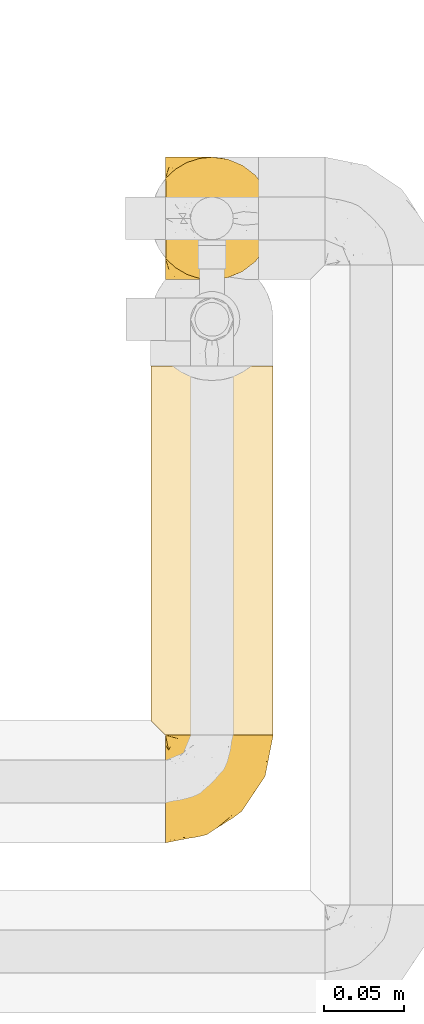
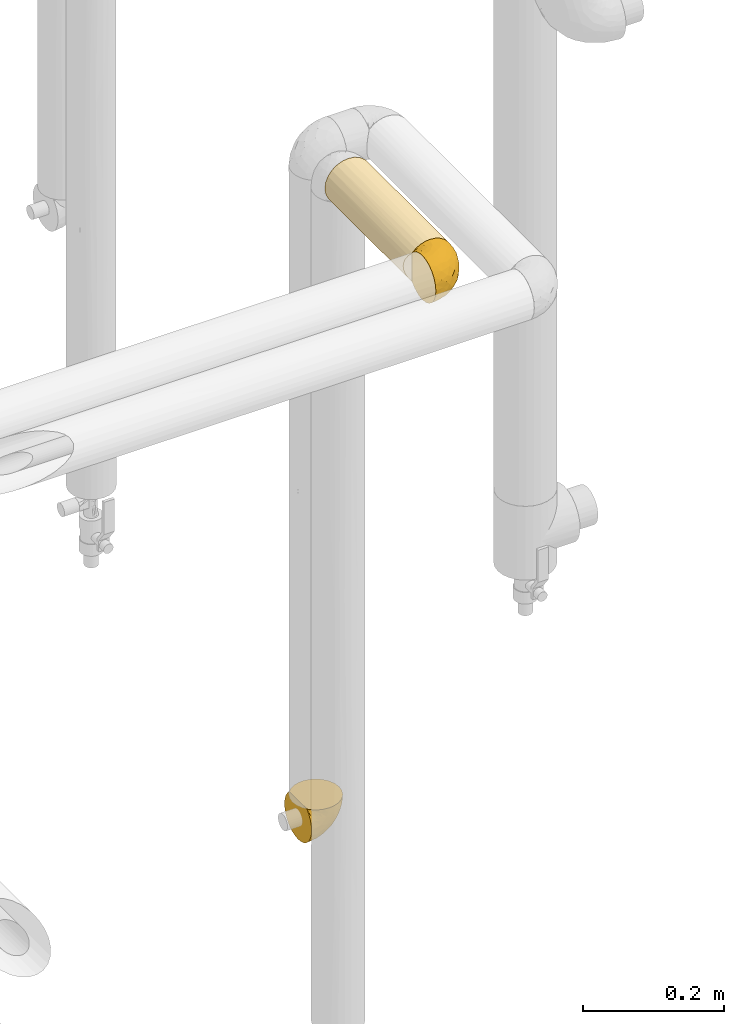
# One storey, part 86 of 827: 3 coverings.
"""IFC2X3 building model written with IfcOpenShell, lengths in millimetres."""

import ifcopenshell
import ifcopenshell.guid

model = None  # the IFC model being written
_history = None  # IfcOwnerHistory: only IFC2X3 demands one
_inside = {}  # id of a spatial element -> (the spatial element, [elements in it])
_under = {}  # id of a project, library or spatial element -> (it, [spatial elements below it])
_declared = {}  # id of a project -> (the project, [libraries it declares])
_typed = {}  # id of a type object -> (the type object, [elements of that type])
_made_of = {}  # id of a material, layer set ... -> (it, [elements and type objects made of it])


def new_model(schema):
    """Start an empty IFC model of exactly this schema.

    Asked for "IFC4X3", IfcOpenShell would pick the latest addendum, in which some entities
    have other attributes; the version numbers below select the first issue.
    IFC2X3 requires an IfcOwnerHistory on every rooted entity: one is made here for all.
    """
    global model, _history
    if schema == "IFC4X3":
        model = ifcopenshell.file(schema_version=(4, 3, 0, 0))
    else:
        model = ifcopenshell.file(schema=schema)
    _inside.clear()
    _under.clear()
    _declared.clear()
    _typed.clear()
    _made_of.clear()
    _history = None
    if model.schema == "IFC2X3":
        org = make("IfcOrganization", Name="unknown")
        user = make(
            "IfcPersonAndOrganization",
            ThePerson=make("IfcPerson", FamilyName="unknown"),
            TheOrganization=org,
        )
        app = make(
            "IfcApplication",
            ApplicationDeveloper=org,
            Version="unknown",
            ApplicationFullName="unknown",
            ApplicationIdentifier="unknown",
        )
        _history = make(
            "IfcOwnerHistory",
            OwningUser=user,
            OwningApplication=app,
            ChangeAction="ADDED",
            CreationDate=0,
        )
    return model


def make(cls, **values):
    """One entity of the class cls with the attributes given. An attribute that is None is left unset."""
    return model.create_entity(
        cls, **{name: value for name, value in values.items() if value is not None}
    )


def entity(cls, *values):
    """Any entity or typed value of the class cls, its attributes in the order of the schema. None: left unset."""
    e = model.create_entity(cls)
    for i, value in enumerate(values):
        if value is not None:
            e[i] = value
    return e


def rooted(cls, **values):
    """An entity with a GlobalId (a new one), such as an element, a storey or a relation."""
    return make(cls, GlobalId=ifcopenshell.guid.new(), OwnerHistory=_history, **values)


def si_unit(unit_type, name, prefix=None):
    """IfcSIUnit, for example si_unit("LENGTHUNIT", "METRE", prefix="MILLI")."""
    return make("IfcSIUnit", UnitType=unit_type, Prefix=prefix, Name=name)


def converted_unit(unit_type, name, factor, base, dimensions=None, offset=None):
    """IfcConversionBasedUnit, such as the inch: factor (a typed value) times the base unit."""
    return make(
        "IfcConversionBasedUnit"
        if offset is None
        else "IfcConversionBasedUnitWithOffset",
        ConversionOffset=offset,
        Dimensions=None
        if dimensions is None
        else entity("IfcDimensionalExponents", *dimensions),
        UnitType=unit_type,
        Name=name,
        ConversionFactor=make(
            "IfcMeasureWithUnit", ValueComponent=factor, UnitComponent=base
        ),
    )


def derived_unit(unit_type, elements):
    """IfcDerivedUnit: a product of units, each with its exponent."""
    return make(
        "IfcDerivedUnit",
        Elements=[
            make("IfcDerivedUnitElement", Unit=unit, Exponent=power)
            for unit, power in elements
        ],
        UnitType=unit_type,
    )


def assignment(units):
    """IfcUnitAssignment: the units of a project."""
    return None if units is None else make("IfcUnitAssignment", Units=units)


def point(xyz):
    """IfcCartesianPoint."""
    return None if xyz is None else make("IfcCartesianPoint", Coordinates=xyz)


def direction(xyz):
    """IfcDirection."""
    return None if xyz is None else make("IfcDirection", DirectionRatios=xyz)


def frame(location, z_axis=None, x_axis=None):
    """IfcAxis2Placement3D, a coordinate frame: its origin and axes. An axis left out is left unset."""
    return make(
        "IfcAxis2Placement3D",
        Location=point(location),
        Axis=direction(z_axis),
        RefDirection=direction(x_axis),
    )


def origin():
    """The frame at (0, 0, 0) with its axes left unset."""
    return frame((0.0, 0.0, 0.0))


def place(relative_to, where):
    """IfcLocalPlacement: puts the frame where relative to a parent placement (None: the world)."""
    return make(
        "IfcLocalPlacement", PlacementRelTo=relative_to, RelativePlacement=where
    )


def context(
    kind, dimensions, precision=None, world=None, true_north=None, identifier=None
):
    """IfcGeometricRepresentationContext, for example the 3D "Model" context."""
    return make(
        "IfcGeometricRepresentationContext",
        ContextIdentifier=identifier,
        ContextType=kind,
        CoordinateSpaceDimension=dimensions,
        Precision=precision,
        WorldCoordinateSystem=world,
        TrueNorth=true_north,
    )


def subcontext(parent, identifier, kind, view, scale=None):
    """IfcGeometricRepresentationSubContext, for example "Body" below "Model"."""
    return make(
        "IfcGeometricRepresentationSubContext",
        ContextIdentifier=identifier,
        ContextType=kind,
        ParentContext=parent,
        TargetScale=scale,
        TargetView=view,
    )


def project(units=None, contexts=None):
    """IfcProject with its units and contexts."""
    return rooted(
        "IfcProject",
        Name="project",
        RepresentationContexts=contexts,
        UnitsInContext=assignment(units),
    )


def spatial(cls, under=None, at=None, **own):
    """A site, building, storey or space (cls), placed at a placement, below another one or the project."""
    s = rooted(cls, ObjectPlacement=at, **own)
    if under is not None:
        _under.setdefault(under.id(), (under, []))[1].append(s)
    return s


def faces_of(points, faces, orient=None, outer=None):
    """IfcFace entities. A face is a list of loops; a loop is a list of indices into points, from 0.

    orient and outer hold one flag for each loop. By default every Orientation is true, the
    first loop of a face is its IfcFaceOuterBound and the others are IfcFaceBound.
    """
    made = []
    for i, loops in enumerate(faces):
        bounds = []
        for j, loop in enumerate(loops):
            is_outer = j == 0 if outer is None else outer[i][j]
            bounds.append(
                make(
                    "IfcFaceOuterBound" if is_outer else "IfcFaceBound",
                    Bound=make("IfcPolyLoop", Polygon=[points[k] for k in loop]),
                    Orientation=True if orient is None else orient[i][j],
                )
            )
        made.append(make("IfcFace", Bounds=bounds))
    return made


def faceted_brep(points, faces, orient=None, outer=None, voids=None):
    """IfcFacetedBrep: a solid bounded by flat faces; with voids (closed shells), ...WithVoids."""
    shared = [point(p) for p in points]
    hull = make("IfcClosedShell", CfsFaces=faces_of(shared, faces, orient, outer))
    if voids is None:
        return make("IfcFacetedBrep", Outer=hull)
    return make(
        "IfcFacetedBrepWithVoids",
        Outer=hull,
        Voids=[
            make(cls, CfsFaces=faces_of(shared, fs, o, b)) for cls, fs, o, b in voids
        ],
    )


def shape(context_of_items, identifier, shape_type, items):
    """IfcShapeRepresentation: the items that make up one representation, for example the "Body"."""
    return make(
        "IfcShapeRepresentation",
        ContextOfItems=context_of_items,
        RepresentationIdentifier=identifier,
        RepresentationType=shape_type,
        Items=items,
    )


def made_of(thing, what):
    """Note that an element or type object is made of a material, layer set ...; save() writes the relation."""
    if what is not None:
        _made_of.setdefault(what.id(), (what, []))[1].append(thing)
    return thing


def element(
    cls,
    number,
    at=None,
    inside=None,
    cuts=None,
    type_object=None,
    material=None,
    context=None,
    identifier="Body",
    shape_type=None,
    held_by="IfcProductDefinitionShape",
    body=None,
    shapes=None,
    **own,
):
    """One element of the class cls, such as IfcWall. Its Tag is "e" and its number.

    at: its placement. inside: the storey or other place that contains it. cuts: it is an
    opening in that element (IfcRelVoidsElement). A single representation is given by context,
    identifier, shape_type and body (its items); several are given by shapes. held_by: the class
    of the entity that holds the representations. save() writes the other relations.
    """
    e = rooted(cls, Tag="e%d" % number, ObjectPlacement=at, **own)
    if body is not None:
        shapes = [shape(context, identifier, shape_type, body)]
    if shapes is not None:
        e.Representation = make(held_by, Representations=shapes)
    if inside is not None:
        _inside.setdefault(inside.id(), (inside, []))[1].append(e)
    if cuts is not None:
        rooted(
            "IfcRelVoidsElement", RelatingBuildingElement=cuts, RelatedOpeningElement=e
        )
    if type_object is not None:
        _typed.setdefault(type_object.id(), (type_object, []))[1].append(e)
    return made_of(e, material)


def aggregate(whole, parts):
    """IfcRelAggregates: a whole, such as a stair, and the parts it consists of."""
    return rooted("IfcRelAggregates", RelatingObject=whole, RelatedObjects=parts)


def save(model, path):
    """Write the relations noted so far, then the file.

    IfcRelAggregates (storeys below a building ...), IfcRelContainedInSpatialStructure (elements
    in a storey), IfcRelDefinesByType, IfcRelAssociatesMaterial and IfcRelDeclares: one each for
    every whole, place, type object, material and project.
    """
    for whole, parts in _under.values():
        aggregate(whole, parts)
    for where, things in _inside.values():
        rooted(
            "IfcRelContainedInSpatialStructure",
            RelatedElements=things,
            RelatingStructure=where,
        )
    for kind, things in _typed.values():
        rooted("IfcRelDefinesByType", RelatedObjects=things, RelatingType=kind)
    for what, things in _made_of.values():
        rooted("IfcRelAssociatesMaterial", RelatedObjects=things, RelatingMaterial=what)
    for by, libraries in _declared.values():
        rooted("IfcRelDeclares", RelatingContext=by, RelatedDefinitions=libraries)
    model.write(path)


model = new_model("IFC2X3")

# Units and contexts
model_context = context("Model", 3, precision=0.01, world=origin(), true_north=direction((6.12303176911189e-17, 1.0)))
body_context = subcontext(model_context, "Body", "Model", "MODEL_VIEW")
ifc_project = project(units=[si_unit("LENGTHUNIT", "METRE", prefix="MILLI"), si_unit("AREAUNIT", "SQUARE_METRE"), si_unit("VOLUMEUNIT", "CUBIC_METRE"), converted_unit("PLANEANGLEUNIT", "DEGREE", entity("IfcRatioMeasure", 0.0174532925199433), si_unit("PLANEANGLEUNIT", "RADIAN"), dimensions=[0, 0, 0, 0, 0, 0, 0]), si_unit("MASSUNIT", "GRAM", prefix="KILO"), derived_unit("MASSDENSITYUNIT", [(si_unit("MASSUNIT", "GRAM", prefix="KILO"), 1), (si_unit("LENGTHUNIT", "METRE"), -3)]), derived_unit("MOMENTOFINERTIAUNIT", [(si_unit("LENGTHUNIT", "METRE"), 4)]), si_unit("TIMEUNIT", "SECOND"), si_unit("FREQUENCYUNIT", "HERTZ"), si_unit("THERMODYNAMICTEMPERATUREUNIT", "DEGREE_CELSIUS"), derived_unit("THERMALTRANSMITTANCEUNIT", [(si_unit("MASSUNIT", "GRAM", prefix="KILO"), 1), (si_unit("THERMODYNAMICTEMPERATUREUNIT", "KELVIN"), -1), (si_unit("TIMEUNIT", "SECOND"), -3)]), derived_unit("VOLUMETRICFLOWRATEUNIT", [(si_unit("LENGTHUNIT", "METRE"), 3), (si_unit("TIMEUNIT", "SECOND"), -1)]), derived_unit("MASSFLOWRATEUNIT", [(si_unit("MASSUNIT", "GRAM", prefix="KILO"), 1), (si_unit("TIMEUNIT", "SECOND"), -1)]), derived_unit("ROTATIONALFREQUENCYUNIT", [(si_unit("TIMEUNIT", "SECOND"), -1)]), si_unit("ELECTRICCURRENTUNIT", "AMPERE"), si_unit("ELECTRICVOLTAGEUNIT", "VOLT"), si_unit("POWERUNIT", "WATT"), si_unit("FORCEUNIT", "NEWTON", prefix="KILO"), si_unit("ILLUMINANCEUNIT", "LUX"), si_unit("LUMINOUSFLUXUNIT", "LUMEN"), si_unit("LUMINOUSINTENSITYUNIT", "CANDELA"), derived_unit("USERDEFINED", [(si_unit("MASSUNIT", "GRAM", prefix="KILO"), -1), (si_unit("LENGTHUNIT", "METRE"), -2), (si_unit("TIMEUNIT", "SECOND"), 3), (si_unit("LUMINOUSFLUXUNIT", "LUMEN"), 1)]), derived_unit("LINEARVELOCITYUNIT", [(si_unit("LENGTHUNIT", "METRE"), 1), (si_unit("TIMEUNIT", "SECOND"), -1)]), si_unit("PRESSUREUNIT", "PASCAL"), derived_unit("USERDEFINED", [(si_unit("LENGTHUNIT", "METRE"), -2), (si_unit("MASSUNIT", "GRAM", prefix="KILO"), 1), (si_unit("TIMEUNIT", "SECOND"), -2)]), derived_unit("LINEARFORCEUNIT", [(si_unit("MASSUNIT", "GRAM", prefix="KILO"), 1), (si_unit("LENGTHUNIT", "METRE"), 1), (si_unit("TIMEUNIT", "SECOND"), -2), (si_unit("LENGTHUNIT", "METRE"), -1)]), derived_unit("PLANARFORCEUNIT", [(si_unit("MASSUNIT", "GRAM", prefix="KILO"), 1), (si_unit("LENGTHUNIT", "METRE"), 1), (si_unit("TIMEUNIT", "SECOND"), -2), (si_unit("LENGTHUNIT", "METRE"), -2)])], contexts=[model_context])

# Site, building, storey
site_placement = place(None, origin())
site = spatial("IfcSite", under=ifc_project, at=site_placement, CompositionType="ELEMENT")
building_placement = place(site_placement, origin())
building = spatial("IfcBuilding", under=site, at=building_placement, CompositionType="ELEMENT")
storey_placement = place(building_placement, frame((0.0, 0.0, 28200.0)))
storey = spatial("IfcBuildingStorey", under=building, at=storey_placement, Name="08", CompositionType="ELEMENT", Elevation=28200.0)

# Coverings
covering_1_placement = place(storey_placement, frame((18855.44, 12179.47, 709.95)))
element("IfcCovering", 1, at=covering_1_placement, inside=storey, Name=":ADSK_", ObjectType=":ADSK_", PredefinedType="INSULATION", context=body_context, shape_type="Brep", body=[
    faceted_brep([(1.6, 74.68, 23.36), (1.6, 70.1, 16.07), (1.6, 64.01, 9.98), (1.6, 56.72, 5.4), (1.6, 48.6, 2.56), (1.6, 40.05, 1.6), (1.6, 31.49, 2.56), (1.6, 23.36, 5.41), (1.6, 16.07, 9.99), (1.6, 9.98, 16.08), (1.6, 5.4, 23.37), (1.6, 2.56, 31.49), (1.6, 1.6, 40.05), (1.6, 2.46, 48.15), (1.6, 5.01, 55.88), (1.6, 9.13, 62.9), (1.6, 14.62, 68.89), (1.6, 16.82, 68.89), (1.6, 18.56, 68.89), (1.6, 20.52, 68.89), (1.6, 22.49, 68.89), (1.6, 24.46, 68.89), (1.6, 26.42, 68.89), (1.6, 28.39, 68.89), (1.6, 30.36, 68.89), (1.6, 32.55, 68.89), (1.6, 34.75, 68.89), (1.6, 36.94, 68.89), (1.6, 39.13, 68.89), (1.6, 41.33, 68.89), (1.6, 43.52, 68.89), (1.6, 45.72, 68.89), (1.6, 47.91, 68.89), (1.6, 50.11, 68.89), (1.6, 52.3, 68.89), (1.6, 54.49, 68.89), (1.6, 56.69, 68.89), (1.6, 58.88, 68.89), (1.6, 61.08, 68.89), (1.6, 63.27, 68.89), (1.6, 65.47, 68.89), (1.6, 70.97, 62.89), (1.6, 75.09, 55.86), (1.6, 77.64, 48.13), (1.6, 78.5, 40.05), (1.6, 77.53, 31.49), (1.85, 14.62, 69.15), (7.85, 9.12, 69.15), (14.87, 5.0, 69.15), (22.6, 2.46, 69.15), (30.7, 1.6, 69.15), (40.65, 2.91, 69.15), (49.92, 6.75, 69.15), (57.88, 12.86, 69.15), (63.99, 20.82, 69.15), (67.84, 30.09, 69.15), (69.15, 40.05, 69.15), (67.84, 50.0, 69.15), (63.99, 59.27, 69.15), (57.88, 67.23, 69.15), (49.92, 73.34, 69.15), (40.65, 77.19, 69.15), (30.7, 78.5, 69.15), (22.6, 77.63, 69.15), (14.87, 75.09, 69.15), (7.85, 70.97, 69.15), (1.85, 65.47, 69.15), (1.85, 63.27, 69.15), (1.85, 62.29, 69.15), (1.85, 60.7, 69.15), (1.85, 59.11, 69.15), (1.85, 57.52, 69.15), (1.85, 55.93, 69.15), (1.85, 54.34, 69.15), (1.85, 52.76, 69.15), (1.85, 51.17, 69.15), (1.85, 49.58, 69.15), (1.85, 47.99, 69.15), (1.85, 46.4, 69.15), (1.85, 44.81, 69.15), (1.85, 43.22, 69.15), (1.85, 41.63, 69.15), (1.85, 40.05, 69.15), (1.85, 38.46, 69.15), (1.85, 36.87, 69.15), (1.85, 35.28, 69.15), (1.85, 33.69, 69.15), (1.85, 32.1, 69.15), (1.85, 30.51, 69.15), (1.85, 28.92, 69.15), (1.85, 27.33, 69.15), (1.85, 25.37, 69.15), (1.85, 23.4, 69.15), (1.85, 21.21, 69.15), (1.85, 19.01, 69.15), (1.85, 16.82, 69.15), (1.77, 42.32, 68.96), (1.78, 44.02, 68.97), (1.77, 47.13, 68.97), (1.77, 48.74, 68.97), (1.76, 23.57, 68.95), (1.77, 25.13, 68.96), (1.79, 61.34, 68.98), (1.78, 22.02, 68.97), (1.78, 29.72, 68.97), (1.78, 56.73, 68.98), (1.78, 55.14, 68.97), (1.78, 37.66, 68.97), (1.74, 64.12, 68.94), (1.78, 28.13, 68.98), (1.78, 26.62, 68.98), (1.77, 31.46, 68.96), (1.78, 16.16, 68.97), (1.78, 39.16, 68.98), (1.78, 50.37, 68.98), (1.77, 17.69, 68.97), (1.77, 19.17, 68.96), (1.77, 62.78, 68.97), (1.78, 58.35, 68.97), (1.78, 45.53, 68.98), (1.77, 59.91, 68.96), (1.77, 65.47, 68.97), (1.72, 65.47, 68.94), (1.66, 65.47, 68.92), (1.77, 14.62, 68.97), (1.8, 14.62, 69.02), (1.82, 14.62, 69.08), (1.79, 20.59, 68.98), (1.78, 32.99, 68.97), (1.79, 34.48, 68.98), (1.78, 51.91, 68.97), (1.82, 65.47, 69.08), (1.8, 65.47, 69.02), (1.76, 53.48, 68.96), (1.66, 14.62, 68.92), (1.72, 14.62, 68.94), (1.78, 40.77, 68.97), (1.77, 35.97, 68.96), (9.41, 7.84, 67.02), (17.65, 3.53, 63.33), (7.41, 8.32, 64.61), (15.21, 2.19, 51.4), (7.41, 3.53, 53.1), (16.15, 1.6, 43.94), (28.75, 1.6, 61.87), (13.67, 4.57, 61.54), (12.79, 3.96, 57.95), (19.18, 2.28, 56.12), (29.16, 1.6, 63.4), (9.04, 7.69, 65.41), (5.74, 8.32, 63.04), (3.72, 7.84, 61.33), (8.87, 1.6, 41.99), (21.47, 1.6, 49.27), (26.8, 1.6, 54.6), (9.53, 4.34, 56.6), (7.34, 1.6, 41.58), (37.63, 29.63, 13.72), (17.92, 27.34, 5.82), (27.45, 40.05, 6.74), (37.01, 2.39, 58.82), (34.22, 2.43, 51.58), (45.87, 9.07, 42.09), (56.57, 16.64, 46.12), (52.31, 9.54, 55.56), (42.07, 4.52, 52.38), (44.74, 4.52, 61.54), (21.49, 7.49, 23.76), (11.02, 7.49, 20.5), (15.64, 12.85, 14.64), (26.02, 2.35, 41.77), (36.59, 22.66, 16.28), (65.49, 32.9, 49.4), (63.99, 25.33, 52.34), (15.2, 40.05, 4.3), (60.27, 16.64, 58.67), (45.25, 19.99, 25.26), (35.21, 16.37, 20.17), (22.52, 3.26, 34.7), (12.03, 3.75, 28.67), (13.32, 19.58, 8.62), (35.9, 7.5, 33.37), (33.87, 4.04, 41.35), (25.73, 13.94, 17.15), (26.34, 19.58, 12.68), (46.78, 28.21, 21.47), (59.54, 24.75, 41.11), (60.18, 31.42, 37.53), (53.93, 26.2, 30.64), (53.36, 33.36, 26.66), (49.36, 40.05, 21.38), (38.4, 40.05, 14.06), (66.44, 40.05, 55.54), (50.09, 16.14, 35.17), (41.08, 12.85, 29.04), (31.14, 10.47, 24.34), (28.19, 6.49, 29.33), (64.0, 40.05, 43.3), (56.68, 40.05, 32.34), (43.9, 75.57, 57.75), (65.46, 47.37, 49.41), (52.22, 52.91, 27.85), (37.61, 50.46, 13.7), (15.64, 67.23, 14.63), (13.31, 60.5, 8.61), (50.02, 70.55, 48.85), (59.28, 63.45, 54.13), (53.05, 62.61, 37.84), (21.48, 72.6, 23.75), (11.01, 72.6, 20.49), (12.03, 76.34, 28.66), (41.02, 59.34, 20.83), (35.39, 77.76, 55.15), (26.8, 78.5, 54.6), (28.75, 78.5, 61.87), (7.34, 78.5, 41.58), (65.81, 53.16, 57.58), (53.28, 70.55, 59.91), (59.8, 48.88, 36.94), (61.82, 54.76, 45.72), (17.91, 52.74, 5.82), (41.4, 71.93, 37.91), (40.48, 75.79, 50.18), (26.34, 60.5, 12.67), (31.68, 77.86, 49.29), (27.68, 77.64, 42.64), (16.15, 78.5, 43.94), (21.47, 78.5, 49.27), (28.05, 67.23, 19.45), (22.54, 76.82, 34.7), (8.87, 78.5, 41.99), (37.3, 77.8, 62.29), (41.07, 67.23, 29.01), (32.24, 73.2, 31.47), (47.4, 67.66, 37.18), (35.77, 75.99, 43.45), (17.65, 76.57, 63.33), (11.06, 73.21, 67.23), (8.55, 71.93, 66.07), (6.63, 71.07, 65.22), (12.77, 75.09, 61.99), (12.79, 76.13, 57.95), (7.41, 76.57, 53.09), (18.97, 77.69, 56.84), (3.72, 72.26, 61.33), (5.76, 71.77, 63.06), (15.21, 77.9, 51.41), (9.52, 75.75, 56.61)], [[[0, 1, 2, 3, 4, 5, 6, 7, 8, 9, 10, 11, 12, 13, 14, 15, 16, 17, 18, 19, 20, 21, 22, 23, 24, 25, 26, 27, 28, 29, 30, 31, 32, 33, 34, 35, 36, 37, 38, 39, 40, 41, 42, 43, 44, 45]], [[46, 47, 48, 49, 50, 51, 52, 53, 54, 55, 56, 57, 58, 59, 60, 61, 62, 63, 64, 65, 66, 67, 68, 69, 70, 71, 72, 73, 74, 75, 76, 77, 78, 79, 80, 81, 82, 83, 84, 85, 86, 87, 88, 89, 90, 91, 92, 93, 94, 95]], [[96, 97, 30]], [[98, 77, 99]], [[100, 101, 21]], [[69, 68, 102]], [[20, 19, 103]], [[24, 23, 104]], [[20, 103, 100]], [[72, 105, 106]], [[84, 83, 107]], [[89, 88, 104]], [[108, 67, 66]], [[109, 110, 90]], [[111, 25, 24]], [[112, 17, 16]], [[82, 113, 83]], [[109, 23, 22]], [[114, 76, 75]], [[105, 36, 106]], [[104, 111, 24]], [[18, 115, 116]], [[97, 96, 80]], [[67, 108, 117]], [[105, 71, 118]], [[31, 97, 119]], [[102, 120, 69]], [[108, 121, 122, 123, 40]], [[112, 95, 115]], [[17, 115, 18]], [[94, 116, 115]], [[117, 68, 67]], [[38, 117, 39]], [[112, 124, 125, 126, 46]], [[17, 112, 115]], [[70, 120, 118]], [[39, 117, 108]], [[120, 38, 37]], [[120, 37, 118]], [[120, 70, 69]], [[116, 94, 127]], [[128, 86, 129]], [[117, 38, 102]], [[74, 130, 75]], [[99, 33, 32]], [[115, 95, 94]], [[39, 108, 40]], [[108, 66, 131, 132, 121]], [[105, 72, 71]], [[118, 37, 36]], [[71, 70, 118]], [[35, 106, 36]], [[36, 105, 118]], [[35, 133, 106]], [[74, 73, 133]], [[106, 133, 73]], [[99, 114, 33]], [[133, 35, 34]], [[73, 72, 106]], [[95, 112, 46]], [[112, 16, 134, 135, 124]], [[130, 114, 75]], [[99, 76, 114]], [[114, 130, 33]], [[34, 33, 130]], [[78, 77, 98]], [[98, 119, 78]], [[130, 133, 34]], [[133, 130, 74]], [[79, 97, 80]], [[98, 99, 32]], [[98, 32, 31]], [[77, 76, 99]], [[97, 79, 119]], [[136, 96, 29]], [[30, 97, 31]], [[136, 29, 28]], [[81, 80, 96]], [[29, 96, 30]], [[31, 119, 98]], [[119, 79, 78]], [[96, 136, 81]], [[82, 81, 136]], [[113, 107, 83]], [[84, 107, 137]], [[107, 27, 137]], [[113, 28, 107]], [[27, 107, 28]], [[85, 84, 137]], [[137, 27, 26]], [[113, 136, 28]], [[136, 113, 82]], [[109, 89, 104]], [[86, 85, 129]], [[89, 109, 90]], [[111, 87, 128]], [[26, 129, 137]], [[88, 111, 104]], [[25, 111, 128]], [[22, 110, 109]], [[23, 109, 104]], [[110, 91, 90]], [[100, 92, 101]], [[110, 22, 101]], [[91, 110, 101]], [[116, 19, 18]], [[111, 88, 87]], [[127, 103, 19]], [[25, 128, 26]], [[86, 128, 87]], [[128, 129, 26]], [[137, 129, 85]], [[120, 102, 38]], [[117, 102, 68]], [[91, 101, 92]], [[21, 101, 22]], [[93, 92, 103]], [[100, 21, 20]], [[100, 103, 92]], [[127, 93, 103]], [[93, 127, 94]], [[116, 127, 19]], [[126, 138, 47]], [[48, 138, 139]], [[140, 125, 124]], [[141, 142, 143]], [[144, 49, 139]], [[145, 140, 146]], [[48, 139, 49]], [[139, 145, 147]], [[49, 144, 148, 50]], [[126, 125, 149]], [[14, 13, 142]], [[150, 146, 140]], [[149, 140, 145]], [[151, 150, 135]], [[151, 14, 142]], [[16, 15, 134]], [[13, 152, 142]], [[124, 150, 140]], [[141, 143, 153]], [[14, 151, 15]], [[15, 151, 134]], [[47, 46, 126]], [[139, 154, 144]], [[138, 48, 47]], [[125, 140, 149]], [[135, 134, 151]], [[146, 155, 141]], [[145, 146, 147]], [[149, 139, 138]], [[147, 153, 154]], [[147, 146, 141]], [[139, 147, 154]], [[139, 149, 145]], [[149, 138, 126]], [[147, 141, 153]], [[146, 150, 155]], [[151, 155, 150]], [[142, 141, 155]], [[13, 12, 156, 152]], [[152, 143, 142]], [[151, 142, 155]], [[150, 124, 135]], [[157, 158, 159]], [[160, 154, 161]], [[162, 163, 164]], [[165, 166, 160]], [[167, 168, 169]], [[153, 170, 161]], [[156, 12, 11]], [[158, 157, 171]], [[172, 55, 173]], [[158, 6, 174]], [[175, 54, 53]], [[52, 166, 164]], [[52, 164, 53]], [[54, 175, 173]], [[166, 52, 51]], [[176, 177, 171]], [[178, 143, 179]], [[156, 11, 179]], [[8, 7, 180]], [[169, 9, 8]], [[179, 143, 152, 156]], [[179, 11, 10]], [[168, 179, 10]], [[181, 162, 182]], [[179, 167, 178]], [[183, 184, 177]], [[183, 169, 184]], [[176, 171, 185]], [[172, 186, 187]], [[158, 7, 6]], [[159, 158, 174]], [[184, 180, 158]], [[54, 173, 55]], [[180, 169, 8]], [[188, 189, 187]], [[9, 168, 10]], [[186, 188, 187]], [[190, 157, 159, 191]], [[55, 172, 192]], [[176, 193, 194]], [[161, 170, 182]], [[162, 164, 165]], [[175, 164, 163]], [[51, 50, 148]], [[167, 195, 196]], [[178, 182, 170]], [[6, 5, 174]], [[158, 180, 7]], [[169, 180, 184]], [[169, 168, 9]], [[179, 168, 167]], [[182, 162, 165]], [[162, 194, 193]], [[161, 165, 160]], [[195, 181, 196]], [[192, 172, 197]], [[192, 56, 55]], [[189, 190, 198]], [[198, 197, 187]], [[172, 187, 197]], [[185, 189, 188]], [[198, 187, 189]], [[186, 172, 173]], [[173, 163, 186]], [[193, 186, 163]], [[176, 185, 188]], [[185, 157, 190]], [[188, 186, 193]], [[177, 176, 194]], [[188, 193, 176]], [[162, 193, 163]], [[195, 177, 194]], [[171, 177, 184]], [[181, 195, 194]], [[183, 167, 169]], [[162, 181, 194]], [[196, 182, 178]], [[158, 171, 184]], [[171, 157, 185]], [[177, 195, 183]], [[167, 183, 195]], [[182, 196, 181]], [[178, 170, 143]], [[178, 167, 196]], [[164, 175, 53]], [[173, 175, 163]], [[160, 51, 148]], [[164, 166, 165]], [[51, 160, 166]], [[160, 148, 144, 154]], [[153, 161, 154]], [[182, 165, 161]], [[190, 189, 185]], [[143, 170, 153]], [[60, 199, 61]], [[197, 200, 192]], [[201, 190, 202]], [[200, 57, 192]], [[203, 204, 2]], [[205, 206, 207]], [[208, 209, 210]], [[211, 207, 201]], [[212, 213, 214]], [[45, 215, 210]], [[216, 206, 58]], [[45, 44, 215]], [[59, 217, 60]], [[60, 217, 199]], [[0, 45, 210]], [[218, 201, 219]], [[202, 159, 220]], [[205, 221, 222]], [[223, 204, 203]], [[1, 203, 2]], [[57, 200, 216]], [[220, 3, 204]], [[220, 174, 4]], [[1, 0, 209]], [[212, 224, 213]], [[225, 226, 227]], [[228, 223, 203]], [[208, 210, 229]], [[210, 226, 229]], [[3, 220, 4]], [[58, 206, 59]], [[209, 203, 1]], [[202, 220, 223]], [[228, 203, 208]], [[202, 211, 201]], [[3, 2, 204]], [[202, 190, 191, 159]], [[210, 215, 230, 226]], [[199, 212, 231]], [[232, 233, 221]], [[233, 208, 229]], [[207, 206, 219]], [[217, 206, 205]], [[227, 224, 225]], [[233, 232, 228]], [[201, 207, 219]], [[234, 232, 221]], [[218, 219, 200]], [[202, 223, 211]], [[174, 220, 159]], [[174, 5, 4]], [[61, 231, 62]], [[220, 204, 223]], [[210, 209, 0]], [[203, 209, 208]], [[225, 233, 229]], [[224, 227, 213]], [[221, 233, 235]], [[57, 56, 192]], [[198, 218, 197]], [[200, 219, 216]], [[201, 198, 190]], [[197, 218, 200]], [[198, 201, 218]], [[206, 216, 219]], [[58, 57, 216]], [[231, 212, 214]], [[222, 212, 199]], [[228, 211, 223]], [[207, 211, 232]], [[62, 231, 214]], [[199, 231, 61]], [[233, 228, 208]], [[211, 228, 232]], [[222, 221, 235]], [[234, 205, 207]], [[206, 217, 59]], [[199, 217, 205]], [[205, 222, 199]], [[224, 222, 235]], [[222, 224, 212]], [[224, 235, 225]], [[233, 225, 235]], [[226, 225, 229]], [[205, 234, 221]], [[207, 232, 234]], [[63, 214, 236]], [[214, 213, 236]], [[214, 63, 62]], [[237, 236, 238]], [[238, 132, 131]], [[236, 237, 64]], [[239, 240, 241]], [[63, 236, 64]], [[131, 66, 65]], [[237, 131, 65]], [[242, 230, 43]], [[237, 65, 64]], [[239, 121, 132]], [[42, 242, 43]], [[241, 240, 243]], [[41, 123, 244]], [[43, 230, 215, 44]], [[244, 122, 245]], [[227, 246, 243]], [[241, 243, 246]], [[121, 239, 245]], [[41, 40, 123]], [[132, 238, 239]], [[244, 42, 41]], [[131, 237, 238]], [[240, 239, 238]], [[245, 239, 241]], [[247, 241, 246]], [[247, 244, 245]], [[238, 236, 240]], [[243, 236, 213]], [[236, 243, 240]], [[226, 246, 227]], [[243, 213, 227]], [[226, 242, 246]], [[241, 247, 245]], [[246, 242, 247]], [[244, 247, 242]], [[242, 226, 230]], [[42, 244, 242]], [[122, 244, 123]], [[122, 121, 245]]]),
])
covering_2_placement = place(storey_placement, frame((18846.14, 11893.68, 1860.0)))
element("IfcCovering", 2, at=covering_2_placement, inside=storey, Name=":ADSK_", ObjectType=":ADSK_", PredefinedType="INSULATION", context=body_context, shape_type="Brep", body=[
    faceted_brep([(23.98, 1.6, 5.09), (31.79, 1.6, 2.48), (40.0, 1.6, 1.6), (49.93, 1.6, 2.9), (59.2, 1.6, 6.74), (67.15, 1.6, 12.84), (73.25, 1.6, 20.8), (77.09, 1.6, 30.06), (78.4, 1.6, 40.0), (77.09, 1.6, 49.93), (73.25, 1.6, 59.2), (67.15, 1.6, 67.15), (59.2, 1.6, 73.25), (49.93, 1.6, 77.09), (40.0, 1.6, 78.4), (31.79, 1.6, 77.51), (23.98, 1.6, 74.9), (16.91, 1.6, 70.68), (10.9, 1.6, 65.05), (10.9, 1.6, 14.94), (16.91, 1.6, 9.31), (14.94, 233.4, 10.9), (9.31, 233.4, 16.91), (5.09, 233.4, 23.98), (2.48, 233.4, 31.79), (1.6, 233.4, 40.0), (2.9, 233.4, 49.93), (6.74, 233.4, 59.2), (12.84, 233.4, 67.15), (20.8, 233.4, 73.25), (30.06, 233.4, 77.09), (40.0, 233.4, 78.4), (49.93, 233.4, 77.09), (59.2, 233.4, 73.25), (67.15, 233.4, 67.15), (73.25, 233.4, 59.2), (77.09, 233.4, 49.93), (78.4, 233.4, 40.0), (77.51, 233.4, 31.79), (74.9, 233.4, 23.98), (70.68, 233.4, 16.91), (65.05, 233.4, 10.9), (2.2, 10.29, 33.21), (4.0, 8.5, 26.63), (6.92, 5.57, 20.48), (1.6, 10.9, 40.0), (20.48, 229.42, 6.92), (26.63, 226.5, 4.0), (33.21, 224.7, 2.2), (40.0, 224.1, 1.6), (46.78, 224.7, 2.2), (53.36, 226.5, 4.0), (59.51, 229.42, 6.92), (4.0, 8.5, 53.36), (2.2, 10.29, 46.78), (6.92, 5.57, 59.51)], [[[0, 1, 2, 3, 4, 5, 6, 7, 8, 9, 10, 11, 12, 13, 14, 15, 16, 17, 18, 19, 20]], [[21, 22, 23, 24, 25, 26, 27, 28, 29, 30, 31, 32, 33, 34, 35, 36, 37, 38, 39, 40, 41]], [[25, 24, 42]], [[24, 23, 43]], [[44, 23, 22]], [[42, 45, 25]], [[44, 43, 23]], [[19, 44, 22]], [[42, 24, 43]], [[22, 21, 19]], [[21, 46, 20]], [[47, 48, 1]], [[46, 47, 0]], [[20, 46, 0]], [[48, 2, 1]], [[1, 0, 47]], [[2, 48, 49]], [[21, 20, 19]], [[50, 51, 3]], [[52, 41, 4]], [[51, 52, 4]], [[49, 50, 2]], [[2, 50, 3]], [[51, 4, 3]], [[41, 5, 4]], [[6, 40, 39]], [[7, 39, 38]], [[8, 38, 37]], [[5, 40, 6]], [[6, 39, 7]], [[38, 8, 7]], [[40, 5, 41]], [[9, 8, 37, 36]], [[10, 9, 36, 35]], [[35, 34, 11, 10]], [[13, 12, 33, 32]], [[14, 13, 32, 31]], [[34, 33, 12, 11]], [[15, 31, 30]], [[16, 30, 29]], [[17, 29, 28]], [[14, 31, 15]], [[15, 30, 16]], [[29, 17, 16]], [[28, 18, 17]], [[53, 27, 26]], [[26, 25, 54]], [[45, 54, 25]], [[55, 18, 27]], [[54, 53, 26]], [[55, 27, 53]], [[27, 18, 28]], [[45, 42, 43, 44, 19, 18, 55, 53, 54]], [[51, 50, 49, 48, 47, 46, 21, 41, 52]]]),
])
covering_3_placement = place(storey_placement, frame((18855.44, 11826.13, 1859.95)))
element("IfcCovering", 3, at=covering_3_placement, inside=storey, Name=":ADSK_", ObjectType=":ADSK_", PredefinedType="INSULATION", context=body_context, shape_type="Brep", body=[
    faceted_brep([(47.38, 69.15, 74.68), (54.67, 69.15, 70.1), (60.76, 69.15, 64.01), (65.34, 69.15, 56.72), (68.18, 69.15, 48.6), (69.15, 69.15, 40.05), (68.18, 69.15, 31.49), (65.33, 69.15, 23.36), (60.75, 69.15, 16.07), (54.66, 69.15, 9.98), (47.37, 69.15, 5.4), (39.25, 69.15, 2.56), (30.7, 69.15, 1.6), (22.59, 69.15, 2.46), (14.86, 69.15, 5.01), (7.84, 69.15, 9.13), (1.85, 69.15, 14.62), (1.85, 69.15, 16.82), (1.85, 69.15, 18.56), (1.85, 69.15, 20.52), (1.85, 69.15, 22.49), (1.85, 69.15, 24.46), (1.85, 69.15, 26.42), (1.85, 69.15, 28.39), (1.85, 69.15, 30.36), (1.85, 69.15, 32.55), (1.85, 69.15, 34.75), (1.85, 69.15, 36.94), (1.85, 69.15, 39.13), (1.85, 69.15, 41.33), (1.85, 69.15, 43.52), (1.85, 69.15, 45.72), (1.85, 69.15, 47.91), (1.85, 69.15, 50.11), (1.85, 69.15, 52.3), (1.85, 69.15, 54.49), (1.85, 69.15, 56.69), (1.85, 69.15, 58.88), (1.85, 69.15, 61.08), (1.85, 69.15, 63.27), (1.85, 69.15, 65.47), (7.85, 69.15, 70.97), (14.88, 69.15, 75.09), (22.61, 69.15, 77.64), (30.7, 69.15, 78.5), (39.26, 69.15, 77.53), (1.6, 68.89, 14.62), (1.6, 62.89, 9.12), (1.6, 55.87, 5.0), (1.6, 48.14, 2.46), (1.6, 40.05, 1.6), (1.6, 30.09, 2.91), (1.6, 20.82, 6.75), (1.6, 12.86, 12.86), (1.6, 6.75, 20.82), (1.6, 2.91, 30.09), (1.6, 1.6, 40.05), (1.6, 2.91, 50.0), (1.6, 6.75, 59.27), (1.6, 12.86, 67.23), (1.6, 20.82, 73.34), (1.6, 30.09, 77.19), (1.6, 40.05, 78.5), (1.6, 48.14, 77.63), (1.6, 55.87, 75.09), (1.6, 62.89, 70.97), (1.6, 68.89, 65.47), (1.6, 68.89, 63.27), (1.6, 68.89, 62.29), (1.6, 68.89, 60.7), (1.6, 68.89, 59.11), (1.6, 68.89, 57.52), (1.6, 68.89, 55.93), (1.6, 68.89, 54.34), (1.6, 68.89, 52.76), (1.6, 68.89, 51.17), (1.6, 68.89, 49.58), (1.6, 68.89, 47.99), (1.6, 68.89, 46.4), (1.6, 68.89, 44.81), (1.6, 68.89, 43.22), (1.6, 68.89, 41.63), (1.6, 68.89, 40.05), (1.6, 68.89, 38.46), (1.6, 68.89, 36.87), (1.6, 68.89, 35.28), (1.6, 68.89, 33.69), (1.6, 68.89, 32.1), (1.6, 68.89, 30.51), (1.6, 68.89, 28.92), (1.6, 68.89, 27.33), (1.6, 68.89, 25.37), (1.6, 68.89, 23.4), (1.6, 68.89, 21.21), (1.6, 68.89, 19.01), (1.6, 68.89, 16.82), (1.78, 68.97, 42.32), (1.77, 68.96, 44.02), (1.78, 68.97, 47.13), (1.77, 68.97, 48.74), (1.79, 68.98, 23.57), (1.78, 68.97, 25.13), (1.76, 68.96, 61.34), (1.77, 68.96, 22.02), (1.77, 68.96, 29.72), (1.76, 68.96, 56.73), (1.77, 68.96, 55.14), (1.77, 68.96, 37.66), (1.8, 69.0, 64.12), (1.76, 68.96, 28.13), (1.77, 68.96, 26.62), (1.78, 68.97, 31.46), (1.77, 68.96, 16.16), (1.77, 68.96, 39.16), (1.76, 68.96, 50.37), (1.77, 68.97, 17.69), (1.78, 68.97, 19.17), (1.77, 68.97, 62.78), (1.77, 68.96, 58.35), (1.77, 68.96, 45.53), (1.78, 68.97, 59.91), (1.77, 68.97, 65.47), (1.8, 69.02, 65.47), (1.82, 69.08, 65.47), (1.77, 68.97, 14.62), (1.72, 68.94, 14.62), (1.66, 68.92, 14.62), (1.76, 68.96, 20.59), (1.77, 68.96, 32.99), (1.76, 68.95, 34.48), (1.77, 68.96, 51.91), (1.66, 68.92, 65.47), (1.72, 68.94, 65.47), (1.78, 68.98, 53.48), (1.82, 69.08, 14.62), (1.8, 69.02, 14.62), (1.77, 68.96, 40.77), (1.78, 68.97, 35.97), (3.72, 61.33, 7.84), (7.41, 53.1, 3.53), (6.13, 63.33, 8.32), (21.47, 49.27, 1.6), (19.34, 55.53, 2.19), (26.8, 54.6, 1.6), (8.87, 41.99, 1.6), (9.2, 57.07, 4.57), (12.79, 57.95, 3.96), (14.62, 51.56, 2.28), (7.34, 41.58, 1.6), (5.33, 61.7, 7.69), (17.64, 63.33, 3.53), (7.7, 65.0, 8.32), (9.41, 67.02, 7.84), (28.75, 61.87, 1.6), (16.15, 43.94, 1.6), (14.14, 61.21, 4.34), (29.16, 63.4, 1.6), (57.02, 33.11, 29.63), (64.92, 52.82, 27.34), (64.0, 43.3, 40.05), (11.92, 33.73, 2.39), (19.16, 36.52, 2.43), (28.65, 24.87, 9.07), (24.62, 14.17, 16.64), (15.19, 18.43, 9.54), (18.36, 28.67, 4.52), (9.2, 26.0, 4.52), (46.98, 49.25, 7.49), (50.24, 59.72, 7.49), (56.1, 55.1, 12.85), (28.97, 44.72, 2.35), (54.46, 34.15, 22.66), (21.34, 5.25, 32.9), (18.4, 6.75, 25.33), (66.44, 55.54, 40.05), (12.07, 10.47, 16.64), (45.49, 25.49, 19.99), (50.57, 35.53, 16.37), (36.04, 48.22, 3.26), (42.07, 58.71, 3.75), (62.12, 57.42, 19.58), (37.37, 34.84, 7.5), (29.39, 36.87, 4.04), (53.59, 45.01, 13.94), (58.06, 44.4, 19.58), (49.27, 23.96, 28.21), (29.63, 11.2, 24.75), (33.21, 10.56, 31.42), (40.1, 16.81, 26.2), (44.08, 17.38, 33.36), (49.36, 21.38, 40.05), (56.68, 32.34, 40.05), (15.2, 4.3, 40.05), (35.57, 20.65, 16.14), (41.7, 29.66, 12.85), (46.4, 39.6, 10.47), (41.41, 42.55, 6.49), (27.45, 6.74, 40.05), (38.4, 14.06, 40.05), (12.99, 26.84, 75.57), (21.33, 5.28, 47.37), (42.89, 18.52, 52.91), (57.04, 33.13, 50.46), (56.11, 55.1, 67.23), (62.13, 57.43, 60.5), (21.89, 20.72, 70.55), (16.62, 11.46, 63.45), (32.9, 17.69, 62.61), (46.99, 49.26, 72.6), (50.25, 59.73, 72.6), (42.08, 58.71, 76.34), (49.91, 29.72, 59.34), (15.6, 35.35, 77.76), (16.15, 43.94, 78.5), (8.87, 41.99, 78.5), (29.16, 63.4, 78.5), (13.16, 4.93, 53.16), (10.83, 17.46, 70.55), (33.8, 10.94, 48.88), (25.02, 8.92, 54.76), (64.92, 52.83, 52.74), (32.83, 29.34, 71.93), (20.56, 30.26, 75.79), (58.07, 44.4, 60.5), (21.46, 39.06, 77.86), (28.1, 43.06, 77.64), (26.8, 54.6, 78.5), (21.47, 49.27, 78.5), (51.29, 42.69, 67.23), (36.04, 48.2, 76.82), (28.75, 61.87, 78.5), (8.45, 33.44, 77.8), (41.73, 29.67, 67.23), (39.27, 38.5, 73.2), (33.56, 23.35, 67.66), (27.29, 34.97, 75.99), (7.41, 53.1, 76.57), (3.51, 59.68, 73.21), (4.68, 62.19, 71.93), (5.52, 64.11, 71.07), (8.75, 57.97, 75.09), (12.79, 57.95, 76.13), (17.65, 63.33, 76.57), (13.9, 51.77, 77.69), (9.42, 67.02, 72.26), (7.68, 64.98, 71.77), (19.33, 55.53, 77.9), (14.13, 61.22, 75.75)], [[[0, 1, 2, 3, 4, 5, 6, 7, 8, 9, 10, 11, 12, 13, 14, 15, 16, 17, 18, 19, 20, 21, 22, 23, 24, 25, 26, 27, 28, 29, 30, 31, 32, 33, 34, 35, 36, 37, 38, 39, 40, 41, 42, 43, 44, 45]], [[46, 47, 48, 49, 50, 51, 52, 53, 54, 55, 56, 57, 58, 59, 60, 61, 62, 63, 64, 65, 66, 67, 68, 69, 70, 71, 72, 73, 74, 75, 76, 77, 78, 79, 80, 81, 82, 83, 84, 85, 86, 87, 88, 89, 90, 91, 92, 93, 94, 95]], [[96, 97, 30]], [[98, 77, 99]], [[100, 101, 21]], [[69, 68, 102]], [[20, 19, 103]], [[24, 23, 104]], [[20, 103, 100]], [[72, 105, 106]], [[84, 83, 107]], [[89, 88, 104]], [[108, 67, 66]], [[109, 110, 90]], [[111, 25, 24]], [[112, 17, 16]], [[82, 113, 83]], [[109, 23, 22]], [[114, 76, 75]], [[105, 36, 106]], [[104, 111, 24]], [[18, 115, 116]], [[97, 96, 80]], [[67, 108, 117]], [[105, 71, 118]], [[31, 97, 119]], [[102, 120, 69]], [[108, 121, 122, 123, 40]], [[112, 95, 115]], [[17, 115, 18]], [[94, 116, 115]], [[117, 68, 67]], [[38, 117, 39]], [[112, 124, 125, 126, 46]], [[17, 112, 115]], [[70, 120, 118]], [[39, 117, 108]], [[120, 38, 37]], [[120, 37, 118]], [[120, 70, 69]], [[116, 94, 127]], [[128, 86, 129]], [[117, 38, 102]], [[74, 130, 75]], [[99, 33, 32]], [[115, 95, 94]], [[39, 108, 40]], [[108, 66, 131, 132, 121]], [[105, 72, 71]], [[118, 37, 36]], [[71, 70, 118]], [[35, 106, 36]], [[36, 105, 118]], [[35, 133, 106]], [[74, 73, 133]], [[106, 133, 73]], [[99, 114, 33]], [[133, 35, 34]], [[73, 72, 106]], [[95, 112, 46]], [[112, 16, 134, 135, 124]], [[130, 114, 75]], [[99, 76, 114]], [[114, 130, 33]], [[34, 33, 130]], [[78, 77, 98]], [[98, 119, 78]], [[130, 133, 34]], [[133, 130, 74]], [[79, 97, 80]], [[98, 99, 32]], [[98, 32, 31]], [[77, 76, 99]], [[97, 79, 119]], [[136, 96, 29]], [[30, 97, 31]], [[136, 29, 28]], [[81, 80, 96]], [[29, 96, 30]], [[31, 119, 98]], [[119, 79, 78]], [[96, 136, 81]], [[82, 81, 136]], [[113, 107, 83]], [[84, 107, 137]], [[107, 27, 137]], [[113, 28, 107]], [[27, 107, 28]], [[85, 84, 137]], [[137, 27, 26]], [[113, 136, 28]], [[136, 113, 82]], [[109, 89, 104]], [[86, 85, 129]], [[89, 109, 90]], [[111, 87, 128]], [[26, 129, 137]], [[88, 111, 104]], [[25, 111, 128]], [[22, 110, 109]], [[23, 109, 104]], [[110, 91, 90]], [[100, 92, 101]], [[110, 22, 101]], [[91, 110, 101]], [[116, 19, 18]], [[111, 88, 87]], [[127, 103, 19]], [[25, 128, 26]], [[86, 128, 87]], [[128, 129, 26]], [[137, 129, 85]], [[120, 102, 38]], [[117, 102, 68]], [[91, 101, 92]], [[21, 101, 22]], [[93, 92, 103]], [[100, 21, 20]], [[100, 103, 92]], [[127, 93, 103]], [[93, 127, 94]], [[116, 127, 19]], [[126, 138, 47]], [[48, 138, 139]], [[140, 125, 124]], [[141, 142, 143]], [[144, 49, 139]], [[145, 140, 146]], [[48, 139, 49]], [[139, 145, 147]], [[49, 144, 148, 50]], [[126, 125, 149]], [[14, 13, 150]], [[151, 146, 140]], [[149, 140, 145]], [[152, 151, 135]], [[152, 14, 150]], [[16, 15, 134]], [[13, 153, 150]], [[124, 151, 140]], [[141, 147, 142]], [[14, 152, 15]], [[15, 152, 134]], [[47, 46, 126]], [[139, 154, 144]], [[138, 48, 47]], [[125, 140, 149]], [[135, 134, 152]], [[146, 155, 142]], [[145, 146, 147]], [[149, 139, 138]], [[147, 141, 154]], [[147, 146, 142]], [[139, 147, 154]], [[139, 149, 145]], [[149, 138, 126]], [[155, 146, 151]], [[150, 143, 142]], [[152, 155, 151]], [[150, 142, 155]], [[13, 12, 156, 153]], [[153, 143, 150]], [[152, 150, 155]], [[151, 124, 135]], [[157, 158, 159]], [[160, 154, 161]], [[162, 163, 164]], [[165, 166, 160]], [[167, 168, 169]], [[141, 170, 161]], [[156, 12, 11]], [[158, 157, 171]], [[172, 55, 173]], [[158, 6, 174]], [[175, 54, 53]], [[52, 166, 164]], [[52, 164, 53]], [[54, 175, 173]], [[166, 52, 51]], [[176, 177, 171]], [[178, 143, 179]], [[156, 11, 179]], [[8, 7, 180]], [[169, 9, 8]], [[179, 143, 153, 156]], [[179, 11, 10]], [[168, 179, 10]], [[181, 162, 182]], [[179, 167, 178]], [[183, 184, 177]], [[183, 169, 184]], [[176, 171, 185]], [[172, 186, 187]], [[158, 7, 6]], [[159, 158, 174]], [[184, 180, 158]], [[54, 173, 55]], [[180, 169, 8]], [[188, 189, 187]], [[9, 168, 10]], [[186, 188, 187]], [[190, 157, 159, 191]], [[55, 172, 192]], [[176, 193, 194]], [[161, 170, 182]], [[162, 164, 165]], [[175, 164, 163]], [[51, 50, 148]], [[167, 195, 196]], [[178, 182, 170]], [[6, 5, 174]], [[158, 180, 7]], [[169, 180, 184]], [[169, 168, 9]], [[179, 168, 167]], [[182, 162, 165]], [[162, 194, 193]], [[161, 165, 160]], [[195, 181, 196]], [[192, 172, 197]], [[192, 56, 55]], [[189, 190, 198]], [[198, 197, 187]], [[172, 187, 197]], [[185, 189, 188]], [[198, 187, 189]], [[186, 172, 173]], [[173, 163, 186]], [[193, 186, 163]], [[176, 185, 188]], [[185, 157, 190]], [[188, 186, 193]], [[177, 176, 194]], [[188, 193, 176]], [[162, 193, 163]], [[195, 177, 194]], [[171, 177, 184]], [[181, 195, 194]], [[183, 167, 169]], [[162, 181, 194]], [[196, 182, 178]], [[158, 171, 184]], [[171, 157, 185]], [[177, 195, 183]], [[167, 183, 195]], [[182, 196, 181]], [[178, 170, 143]], [[178, 167, 196]], [[164, 175, 53]], [[173, 175, 163]], [[160, 51, 148]], [[164, 166, 165]], [[51, 160, 166]], [[160, 148, 144, 154]], [[141, 161, 154]], [[182, 165, 161]], [[190, 189, 185]], [[143, 170, 141]], [[60, 199, 61]], [[197, 200, 192]], [[201, 190, 202]], [[200, 57, 192]], [[203, 204, 2]], [[205, 206, 207]], [[208, 209, 210]], [[211, 207, 201]], [[212, 213, 214]], [[45, 215, 210]], [[216, 206, 58]], [[45, 44, 215]], [[59, 217, 60]], [[60, 217, 199]], [[0, 45, 210]], [[218, 201, 219]], [[202, 159, 220]], [[205, 221, 222]], [[223, 204, 203]], [[1, 203, 2]], [[57, 200, 216]], [[220, 3, 204]], [[220, 174, 4]], [[1, 0, 209]], [[212, 224, 213]], [[225, 226, 227]], [[228, 223, 203]], [[208, 210, 229]], [[210, 226, 229]], [[3, 220, 4]], [[58, 206, 59]], [[209, 203, 1]], [[202, 220, 223]], [[228, 203, 208]], [[202, 211, 201]], [[3, 2, 204]], [[202, 190, 191, 159]], [[210, 215, 230, 226]], [[199, 212, 231]], [[232, 233, 221]], [[233, 208, 229]], [[207, 206, 219]], [[217, 206, 205]], [[227, 224, 225]], [[233, 232, 228]], [[201, 207, 219]], [[234, 232, 221]], [[218, 219, 200]], [[202, 223, 211]], [[174, 220, 159]], [[174, 5, 4]], [[61, 231, 62]], [[220, 204, 223]], [[210, 209, 0]], [[203, 209, 208]], [[225, 233, 229]], [[224, 227, 213]], [[221, 233, 235]], [[57, 56, 192]], [[198, 218, 197]], [[200, 219, 216]], [[201, 198, 190]], [[197, 218, 200]], [[198, 201, 218]], [[206, 216, 219]], [[58, 57, 216]], [[231, 212, 214]], [[222, 212, 199]], [[228, 211, 223]], [[207, 211, 232]], [[62, 231, 214]], [[199, 231, 61]], [[233, 228, 208]], [[211, 228, 232]], [[222, 221, 235]], [[234, 205, 207]], [[206, 217, 59]], [[199, 217, 205]], [[205, 222, 199]], [[224, 222, 235]], [[222, 224, 212]], [[224, 235, 225]], [[233, 225, 235]], [[226, 225, 229]], [[205, 234, 221]], [[207, 232, 234]], [[63, 214, 236]], [[214, 213, 236]], [[214, 63, 62]], [[237, 236, 238]], [[238, 132, 131]], [[236, 237, 64]], [[239, 240, 241]], [[63, 236, 64]], [[131, 66, 65]], [[237, 131, 65]], [[242, 230, 43]], [[237, 65, 64]], [[239, 121, 132]], [[42, 242, 43]], [[241, 240, 243]], [[41, 123, 244]], [[43, 230, 215, 44]], [[244, 122, 245]], [[227, 246, 243]], [[241, 247, 245]], [[121, 239, 245]], [[41, 40, 123]], [[132, 238, 239]], [[244, 42, 41]], [[131, 237, 238]], [[240, 239, 238]], [[245, 239, 241]], [[247, 241, 246]], [[247, 244, 245]], [[238, 236, 240]], [[243, 236, 213]], [[236, 243, 240]], [[227, 226, 246]], [[243, 213, 227]], [[242, 246, 226]], [[243, 246, 241]], [[246, 242, 247]], [[244, 247, 242]], [[242, 226, 230]], [[42, 244, 242]], [[122, 244, 123]], [[122, 121, 245]]]),
])

save(model, "model.ifc")
